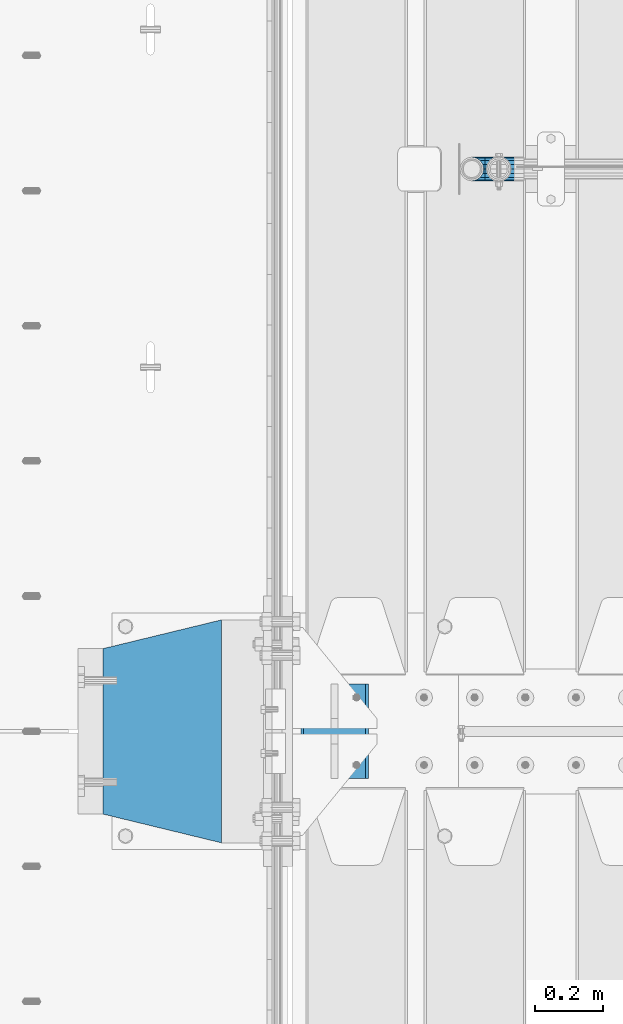
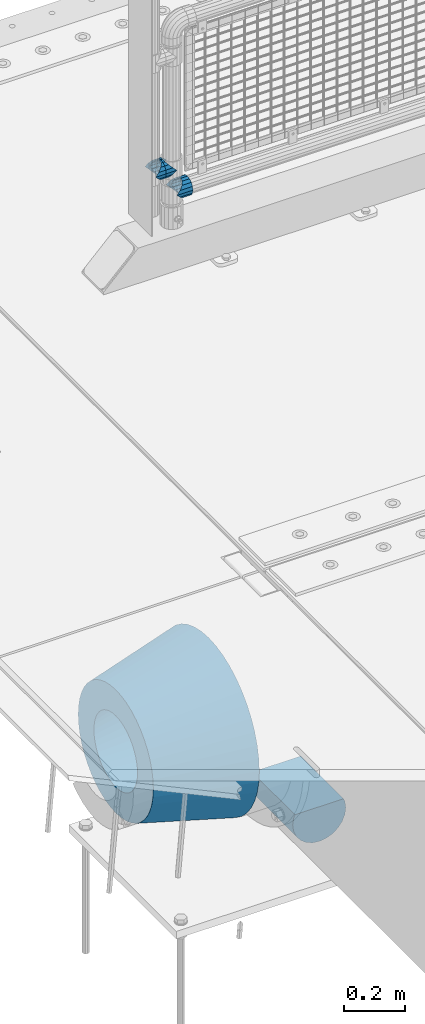
# One storey, part 145 of 257: 5 beams.
"""IFC2X3 building model written with IfcOpenShell, lengths in millimetres."""

from ifc_helpers import new_model, si_unit, frame, origin_with_axes, place, context, subcontext, project, spatial, faceted_brep, material, type_object, element, save


model = new_model("IFC2X3")

# Units and contexts
model_context = context("Model", 3, precision=1e-05, world=origin_with_axes())
body_context = subcontext(model_context, "Body", "Model", "MODEL_VIEW")
ifc_project = project(units=[si_unit("LENGTHUNIT", "METRE", prefix="MILLI"), si_unit("AREAUNIT", "SQUARE_METRE"), si_unit("VOLUMEUNIT", "CUBIC_METRE"), si_unit("MASSUNIT", "GRAM", prefix="KILO"), si_unit("TIMEUNIT", "SECOND"), si_unit("PLANEANGLEUNIT", "RADIAN"), si_unit("SOLIDANGLEUNIT", "STERADIAN"), si_unit("THERMODYNAMICTEMPERATUREUNIT", "DEGREE_CELSIUS"), si_unit("LUMINOUSINTENSITYUNIT", "LUMEN")], contexts=[model_context])

# Site, building, storey
site_placement = place(None, origin_with_axes())
site = spatial("IfcSite", under=ifc_project, at=site_placement, CompositionType="ELEMENT")
building_placement = place(site_placement, origin_with_axes())
building = spatial("IfcBuilding", under=site, at=building_placement, Name="Standard", CompositionType="ELEMENT")
storey_placement = place(building_placement, origin_with_axes())
storey = spatial("IfcBuildingStorey", under=building, at=storey_placement, Name="Undefined", CompositionType="ELEMENT", Elevation=0.0)

# Beams
ifc_material_1 = material(Name="STEEL/S355N")
beam_type_1 = type_object("IfcBeamType", Name="D200", PredefinedType="NOTDEFINED")
beam_1_placement = place(storey_placement, frame((42585.0, 8860.0, -928.0), z_axis=(0.0, 0.0, 1.0), x_axis=(0.0, 1.0, 0.0)))
element("IfcBeam", 1, at=beam_1_placement, inside=storey, type_object=beam_type_1, material=ifc_material_1, ObjectType="D200", context=body_context, shape_type="Brep", body=[
    faceted_brep([(0.0, 100.0, 0.0), (0.0, 96.5925826289094, 25.8819045102521), (280.0, 96.5925826289094, 25.8819045102521), (280.0, 100.0, 0.0), (0.0, 96.5925826289094, -25.8819045102521), (280.0, 96.5925826289094, -25.8819045102521), (0.0, 86.6025403784442, -50.0), (280.0, 86.6025403784442, -50.0), (0.0, 70.7106781186521, -70.7106781186548), (280.0, 70.7106781186521, -70.7106781186548), (0.0, 50.0, -86.6025403784438), (280.0, 50.0, -86.6025403784438), (0.0, 25.88190451025, -96.5925826289067), (280.0, 25.88190451025, -96.5925826289067), (0.0, 0.0, -100.0), (280.0, 0.0, -100.0), (0.0, -25.88190451025, -96.5925826289069), (280.0, -25.88190451025, -96.5925826289069), (0.0, -50.0, -86.6025403784439), (280.0, -50.0, -86.6025403784439), (0.0, -70.7106781186521, -70.7106781186548), (280.0, -70.7106781186521, -70.7106781186548), (0.0, -86.6025403784442, -50.0), (280.0, -86.6025403784442, -50.0), (0.0, -96.5925826289094, -25.8819045102522), (280.0, -96.5925826289094, -25.8819045102522), (0.0, -100.0, 0.0), (280.0, -100.0, 0.0), (0.0, -96.5925826289094, 25.8819045102521), (280.0, -96.5925826289094, 25.8819045102521), (280.0, -91.5731031269243, 38.0), (0.0, -91.5731031269243, 38.0), (0.0, 91.5731031269243, 38.0), (280.0, 91.5731031269243, 38.0)], [[[0, 1, 2, 3]], [[4, 0, 3, 5]], [[6, 4, 5, 7]], [[8, 6, 7, 9]], [[10, 8, 9, 11]], [[12, 10, 11, 13]], [[14, 12, 13, 15]], [[16, 14, 15, 17]], [[18, 16, 17, 19]], [[20, 18, 19, 21]], [[22, 20, 21, 23]], [[24, 22, 23, 25]], [[26, 24, 25, 27]], [[28, 26, 27, 29]], [[28, 29, 30, 31]], [[1, 0, 4, 6, 8, 10, 12, 14, 16, 18, 20, 22, 24, 26, 28, 31, 32]], [[2, 1, 32, 33]], [[29, 27, 25, 23, 21, 19, 17, 15, 13, 11, 9, 7, 5, 3, 2, 33, 30]], [[32, 31, 30, 33]]]),
])
ifc_material_2 = material(Name="Misc_Undefined")
beam_type_2 = type_object("IfcBeamType", PredefinedType="NOTDEFINED")
beam_2_placement = place(storey_placement, frame((43071.0, 10664.5, 298.67), z_axis=(0.0, 1.0, 0.0), x_axis=(1.0, 0.0, 0.0)))
element("IfcBeam", 2, at=beam_2_placement, inside=storey, type_object=beam_type_2, material=ifc_material_2, context=body_context, shape_type="Brep", body=[
    faceted_brep([(0.0, 0.0, 35.1499999999996), (13.4513226476338, 13.4513226476329, 32.4743655677721), (13.4513226476338, -13.4513226476329, 32.4743655677721), (32.4743655677739, -32.4743655677717, -13.4513226476338), (32.4743655677739, -26.8123795176755, -13.4513226476338), (27.1226768591005, -21.4606908090117, -21.4606908090118), (24.8548033587067, -16.3810424080045, -24.8548033587067), (24.8548033587067, -24.8548033587072, -24.8548033587067), (13.4513226476338, -13.4513226476329, -32.4743655677721), (13.4513226476338, 13.4513226476329, -32.4743655677721), (0.0, 0.0, -35.1499999999996), (20.0882031229849, -11.6144421722805, -28.0397438117179), (16.6306603983685, 0.0, -30.3500000000004), (20.0882031229849, 11.6144421722805, -28.0397438117179), (24.8548033587067, 16.3810424080013, -24.8548033587067), (24.8548033587067, 24.8548033587072, -24.8548033587067), (32.4743655677739, 26.8123795176754, -13.4513226476338), (32.4743655677739, 32.4743655677717, -13.4513226476338), (27.1226768591005, 21.4606908090117, -21.4606908090118), (35.1500000000015, 30.35, 0.0), (35.1500000000015, 35.15, 0.0), (32.8397438117172, 28.0397438117175, -11.6144421722802), (32.8397438117172, 28.0397438117175, 11.6144421722802), (32.4743655677739, 26.8123795176755, 13.4513226476338), (32.4743655677739, 32.4743655677717, 13.4513226476338), (27.122676859115, 21.4606908090117, 21.4606908090118), (24.8548033587067, 16.3810424080013, 24.8548033587067), (24.8548033587067, 24.8548033587072, 24.8548033587067), (20.0882031229849, 11.6144421722805, 28.0397438117179), (16.6306603983758, 0.0, 30.3500000000004), (20.0882031229849, -11.6144421722805, 28.0397438117179), (24.8548033587067, -16.3810424080013, 24.8548033587067), (24.8548033587067, -24.8548033587072, 24.8548033587067), (27.122676859115, -21.4606908090117, 21.4606908090118), (32.4743655677739, -26.8123795176754, 13.4513226476338), (32.4743655677739, -32.4743655677717, 13.4513226476338), (32.8397438117172, -28.0397438117175, 11.6144421722802), (35.1500000000015, -30.35, 0.0), (35.1500000000015, -35.1499999999996, 0.0), (32.8397438117172, -28.0397438117175, -11.6144421722802), (60.1500000000015, -24.8548033587072, -24.8548033587067), (60.1500000000015, -32.4743655677717, -13.4513226476338), (60.1500000000015, -13.4513226476329, -32.4743655677721), (60.1500000000015, 0.0, -35.1499999999996), (60.1500000000015, 13.4513226476329, -32.4743655677721), (60.1500000000015, 24.8548033587072, -24.8548033587067), (60.1500000000015, 32.4743655677717, -13.4513226476338), (60.1500000000015, 35.15, 0.0), (60.1500000000015, 32.4743655677717, 13.4513226476338), (60.1500000000015, 24.8548033587072, 24.8548033587067), (60.1500000000015, 13.4513226476329, 32.4743655677721), (60.1500000000015, 0.0, 35.1499999999996), (60.1500000000015, -13.4513226476329, 32.4743655677721), (60.1500000000015, -24.8548033587072, 24.8548033587067), (60.1500000000015, -32.4743655677717, 13.4513226476338), (60.1500000000015, -35.15, 0.0), (60.1500000000015, -21.4606908090117, 21.4606908090118), (60.1500000000015, -11.6144421722805, 28.0397438117179), (60.1500000000015, 0.0, 30.3500000000004), (60.1500000000015, 11.6144421722805, 28.0397438117179), (60.1500000000015, 21.4606908090117, 21.4606908090118), (60.1500000000015, 28.0397438117175, 11.6144421722802), (60.1500000000015, 30.35, 0.0), (60.1500000000015, 28.0397438117175, -11.6144421722802), (60.1500000000015, 21.4606908090117, -21.4606908090118), (60.1500000000015, 11.6144421722805, -28.0397438117179), (60.1500000000015, 0.0, -30.3500000000004), (60.1500000000015, -11.6144421722805, -28.0397438117179), (60.1500000000015, -21.4606908090117, -21.4606908090118), (60.1500000000015, -28.0397438117175, -11.6144421722802), (60.1500000000015, -30.35, 0.0), (60.1500000000015, -28.0397438117175, 11.6144421722802)], [[[0, 1, 2]], [[3, 4, 5, 6, 7]], [[8, 9, 10]], [[7, 6, 11, 12, 13, 14, 15, 9, 8]], [[16, 17, 15, 14, 18]], [[19, 20, 17, 16, 21]], [[22, 23, 24, 20, 19]], [[25, 26, 27, 24, 23]], [[2, 1, 27, 26, 28, 29, 30, 31, 32]], [[32, 31, 33, 34, 35]], [[35, 34, 36, 37, 38]], [[38, 37, 39, 4, 3]], [[40, 41, 3, 7]], [[42, 40, 7, 8]], [[43, 42, 8, 10]], [[44, 43, 10, 9]], [[45, 44, 9, 15]], [[46, 45, 15, 17]], [[47, 46, 17, 20]], [[48, 47, 20, 24]], [[49, 48, 24, 27]], [[50, 49, 27, 1]], [[51, 50, 1, 0]], [[52, 51, 0, 2]], [[53, 52, 2, 32]], [[54, 53, 32, 35]], [[55, 54, 35, 38]], [[41, 55, 38, 3]], [[40, 42, 43, 44, 45, 46, 47, 48, 49, 50, 51, 52, 53, 54, 55, 41], [56, 57, 58, 59, 60, 61, 62, 63, 64, 65, 66, 67, 68, 69, 70, 71]], [[71, 70, 37, 36]], [[33, 56, 71, 36, 34]], [[30, 57, 56, 33, 31]], [[58, 57, 30, 29]], [[59, 58, 29, 28]], [[60, 59, 28, 26, 25]], [[61, 60, 25, 23, 22]], [[62, 61, 22, 19]], [[63, 62, 19, 21]], [[18, 64, 63, 21, 16]], [[13, 65, 64, 18, 14]], [[66, 65, 13, 12]], [[67, 66, 12, 11]], [[68, 67, 11, 6, 5]], [[69, 68, 5, 4, 39]], [[70, 69, 39, 37]]]),
])
beam_3_placement = place(storey_placement, frame((42991.0, 10664.5, 398.669999999999), z_axis=(0.0, -1.0, 0.0), x_axis=(1.0, 0.0, 0.0)))
element("IfcBeam", 3, at=beam_3_placement, inside=storey, type_object=beam_type_2, material=ifc_material_2, context=body_context, shape_type="Brep", body=[
    faceted_brep([(13.4513226476338, -13.4513226476329, -32.4743655677721), (13.4513226476338, 13.4513226476329, -32.4743655677721), (0.0, 0.0, -35.1499999999996), (27.122676859115, 21.4606908090117, 21.4606908090118), (24.8548033587067, 16.3810424080013, 24.8548033587067), (24.8548033587067, 24.8548033587072, 24.8548033587067), (32.4743655677739, 32.4743655677717, 13.4513226476338), (32.4743655677739, 26.8123795176755, 13.4513226476338), (0.0, 0.0, 35.1499999999996), (13.4513226476338, 13.4513226476329, 32.4743655677721), (13.4513226476338, -13.4513226476329, 32.4743655677721), (20.0882031229849, 11.6144421722805, 28.0397438117179), (16.6306603983758, 0.0, 30.3500000000004), (20.0882031229849, -11.6144421722805, 28.0397438117179), (24.8548033587067, -16.3810424080013, 24.8548033587067), (24.8548033587067, -24.8548033587072, 24.8548033587067), (27.122676859115, -21.4606908090117, 21.4606908090118), (32.4743655677739, -26.8123795176754, 13.4513226476338), (32.4743655677739, -32.4743655677717, 13.4513226476338), (32.8397438117172, -28.0397438117175, 11.6144421722802), (35.1500000000015, -30.35, 0.0), (35.1500000000015, -35.1499999999996, 0.0), (32.8397438117172, -28.0397438117175, -11.6144421722802), (32.4743655677739, -26.8123795176755, -13.4513226476338), (32.4743655677739, -32.4743655677717, -13.4513226476338), (27.1226768591005, -21.4606908090117, -21.4606908090118), (24.8548033587067, -16.3810424080045, -24.8548033587067), (24.8548033587067, -24.8548033587072, -24.8548033587067), (20.0882031229849, -11.6144421722805, -28.0397438117179), (16.6306603983685, 0.0, -30.3500000000004), (20.0882031229849, 11.6144421722805, -28.0397438117179), (24.8548033587067, 16.3810424080013, -24.8548033587067), (24.8548033587067, 24.8548033587072, -24.8548033587067), (32.4743655677739, 26.8123795176754, -13.4513226476338), (32.4743655677739, 32.4743655677717, -13.4513226476338), (27.1226768591005, 21.4606908090117, -21.4606908090118), (35.1500000000015, 30.35, 0.0), (35.1500000000015, 35.15, 0.0), (32.8397438117172, 28.0397438117175, -11.6144421722802), (32.8397438117172, 28.0397438117175, 11.6144421722802), (40.1500000000015, -35.15, 0.0), (40.1500000000015, -32.4743655677717, 13.4513226476338), (40.1500000000015, -24.8548033587072, 24.8548033587067), (40.1500000000015, -13.4513226476329, 32.4743655677721), (40.1500000000015, 0.0, 35.1499999999996), (40.1500000000015, 13.4513226476329, 32.4743655677721), (40.1500000000015, 24.8548033587072, 24.8548033587067), (40.1500000000015, 32.4743655677717, 13.4513226476338), (40.1500000000015, 35.15, 0.0), (40.1500000000015, -24.8548033587072, -24.8548033587067), (40.1500000000015, -32.4743655677717, -13.4513226476338), (40.1500000000015, -13.4513226476329, -32.4743655677721), (40.1500000000015, 0.0, -35.1499999999996), (40.1500000000015, 13.4513226476329, -32.4743655677721), (40.1500000000015, 24.8548033587072, -24.8548033587067), (40.1500000000015, 32.4743655677717, -13.4513226476338), (40.1500000000015, -21.4606908090117, 21.4606908090118), (40.1500000000015, -11.6144421722805, 28.0397438117179), (40.1500000000015, 0.0, 30.3500000000004), (40.1500000000015, 11.6144421722805, 28.0397438117179), (40.1500000000015, 21.4606908090117, 21.4606908090118), (40.1500000000015, 28.0397438117175, 11.6144421722802), (40.1500000000015, 30.35, 0.0), (40.1500000000015, 28.0397438117175, -11.6144421722802), (40.1500000000015, 21.4606908090117, -21.4606908090118), (40.1500000000015, 11.6144421722805, -28.0397438117179), (40.1500000000015, 0.0, -30.3500000000004), (40.1500000000015, -11.6144421722805, -28.0397438117179), (40.1500000000015, -21.4606908090117, -21.4606908090118), (40.1500000000015, -28.0397438117175, -11.6144421722802), (40.1500000000015, -30.35, 0.0), (40.1500000000015, -28.0397438117175, 11.6144421722802)], [[[0, 1, 2]], [[3, 4, 5, 6, 7]], [[8, 9, 10]], [[10, 9, 5, 4, 11, 12, 13, 14, 15]], [[15, 14, 16, 17, 18]], [[18, 17, 19, 20, 21]], [[21, 20, 22, 23, 24]], [[24, 23, 25, 26, 27]], [[27, 26, 28, 29, 30, 31, 32, 1, 0]], [[33, 34, 32, 31, 35]], [[36, 37, 34, 33, 38]], [[39, 7, 6, 37, 36]], [[40, 41, 18, 21]], [[41, 42, 15, 18]], [[42, 43, 10, 15]], [[43, 44, 8, 10]], [[44, 45, 9, 8]], [[45, 46, 5, 9]], [[46, 47, 6, 5]], [[47, 48, 37, 6]], [[49, 50, 24, 27]], [[51, 49, 27, 0]], [[52, 51, 0, 2]], [[53, 52, 2, 1]], [[54, 53, 1, 32]], [[55, 54, 32, 34]], [[48, 55, 34, 37]], [[50, 40, 21, 24]], [[49, 51, 52, 53, 54, 55, 48, 47, 46, 45, 44, 43, 42, 41, 40, 50], [56, 57, 58, 59, 60, 61, 62, 63, 64, 65, 66, 67, 68, 69, 70, 71]], [[63, 62, 36, 38]], [[35, 64, 63, 38, 33]], [[30, 65, 64, 35, 31]], [[66, 65, 30, 29]], [[67, 66, 29, 28]], [[68, 67, 28, 26, 25]], [[69, 68, 25, 23, 22]], [[70, 69, 22, 20]], [[71, 70, 20, 19]], [[16, 56, 71, 19, 17]], [[13, 57, 56, 16, 14]], [[58, 57, 13, 12]], [[59, 58, 12, 11]], [[60, 59, 11, 4, 3]], [[61, 60, 3, 7, 39]], [[62, 61, 39, 36]]]),
])
beam_4_placement = place(storey_placement, frame((43071.0, 10664.5, 398.669999999999), z_axis=(0.0, 1.0, 0.0), x_axis=(-1.0, 0.0, 0.0)))
element("IfcBeam", 4, at=beam_4_placement, inside=storey, type_object=beam_type_2, material=ifc_material_2, context=body_context, shape_type="Brep", body=[
    faceted_brep([(13.4513226476338, -13.4513226476329, -32.4743655677721), (13.4513226476338, 13.4513226476329, -32.4743655677721), (0.0, 0.0, -35.1499999999996), (24.8548033587067, -24.8548033587072, 24.8548033587067), (24.8548033587067, -16.3810424080013, 24.8548033587067), (27.122676859115, -21.4606908090117, 21.4606908090118), (32.4743655677739, -26.8123795176754, 13.4513226476338), (32.4743655677739, -32.4743655677717, 13.4513226476338), (32.8397438117172, -28.0397438117175, 11.6144421722802), (35.1500000000015, -30.35, 0.0), (35.1500000000015, -35.1499999999996, 0.0), (32.8397438117172, -28.0397438117175, -11.6144421722802), (32.4743655677739, -26.8123795176755, -13.4513226476338), (32.4743655677739, -32.4743655677717, -13.4513226476338), (27.1226768591005, -21.4606908090117, -21.4606908090118), (24.8548033587067, -16.3810424080045, -24.8548033587067), (24.8548033587067, -24.8548033587072, -24.8548033587067), (20.0882031229849, -11.6144421722805, -28.0397438117179), (16.6306603983685, 0.0, -30.3500000000004), (20.0882031229849, 11.6144421722805, -28.0397438117179), (24.8548033587067, 16.3810424080013, -24.8548033587067), (24.8548033587067, 24.8548033587072, -24.8548033587067), (32.4743655677739, 26.8123795176754, -13.4513226476338), (32.4743655677739, 32.4743655677717, -13.4513226476338), (27.1226768591005, 21.4606908090117, -21.4606908090118), (35.1500000000015, 30.35, 0.0), (35.1500000000015, 35.15, 0.0), (32.8397438117172, 28.0397438117175, -11.6144421722802), (32.8397438117172, 28.0397438117175, 11.6144421722802), (32.4743655677739, 26.8123795176755, 13.4513226476338), (32.4743655677739, 32.4743655677717, 13.4513226476338), (27.122676859115, 21.4606908090117, 21.4606908090118), (24.8548033587067, 16.3810424080013, 24.8548033587067), (24.8548033587067, 24.8548033587072, 24.8548033587067), (0.0, 0.0, 35.1499999999996), (13.4513226476338, 13.4513226476329, 32.4743655677721), (13.4513226476338, -13.4513226476329, 32.4743655677721), (20.0882031229849, 11.6144421722805, 28.0397438117179), (16.6306603983758, 0.0, 30.3500000000004), (20.0882031229849, -11.6144421722805, 28.0397438117179), (40.1500000000015, -35.15, 0.0), (40.1500000000015, -32.4743655677717, 13.4513226476338), (40.1500000000015, -24.8548033587072, 24.8548033587067), (40.1500000000015, -13.4513226476329, 32.4743655677721), (40.1500000000015, 0.0, 35.1499999999996), (40.1500000000015, -24.8548033587072, -24.8548033587067), (40.1500000000015, -32.4743655677717, -13.4513226476338), (40.1500000000015, -13.4513226476329, -32.4743655677721), (40.1500000000015, 0.0, -35.1499999999996), (40.1500000000015, 13.4513226476329, -32.4743655677721), (40.1500000000015, 24.8548033587072, -24.8548033587067), (40.1500000000015, 32.4743655677717, -13.4513226476338), (40.1500000000015, 35.15, 0.0), (40.1500000000015, 32.4743655677717, 13.4513226476338), (40.1500000000015, 24.8548033587072, 24.8548033587067), (40.1500000000015, 13.4513226476329, 32.4743655677721), (40.1500000000015, -21.4606908090117, 21.4606908090118), (40.1500000000015, -11.6144421722805, 28.0397438117179), (40.1500000000015, 0.0, 30.3500000000004), (40.1500000000015, 11.6144421722805, 28.0397438117179), (40.1500000000015, 21.4606908090117, 21.4606908090118), (40.1500000000015, 28.0397438117175, 11.6144421722802), (40.1500000000015, 30.35, 0.0), (40.1500000000015, 28.0397438117175, -11.6144421722802), (40.1500000000015, 21.4606908090117, -21.4606908090118), (40.1500000000015, 11.6144421722805, -28.0397438117179), (40.1500000000015, 0.0, -30.3500000000004), (40.1500000000015, -11.6144421722805, -28.0397438117179), (40.1500000000015, -21.4606908090117, -21.4606908090118), (40.1500000000015, -28.0397438117175, -11.6144421722802), (40.1500000000015, -30.35, 0.0), (40.1500000000015, -28.0397438117175, 11.6144421722802)], [[[0, 1, 2]], [[3, 4, 5, 6, 7]], [[7, 6, 8, 9, 10]], [[10, 9, 11, 12, 13]], [[13, 12, 14, 15, 16]], [[16, 15, 17, 18, 19, 20, 21, 1, 0]], [[22, 23, 21, 20, 24]], [[25, 26, 23, 22, 27]], [[28, 29, 30, 26, 25]], [[31, 32, 33, 30, 29]], [[34, 35, 36]], [[36, 35, 33, 32, 37, 38, 39, 4, 3]], [[40, 41, 7, 10]], [[41, 42, 3, 7]], [[42, 43, 36, 3]], [[43, 44, 34, 36]], [[45, 46, 13, 16]], [[47, 45, 16, 0]], [[48, 47, 0, 2]], [[49, 48, 2, 1]], [[50, 49, 1, 21]], [[51, 50, 21, 23]], [[52, 51, 23, 26]], [[53, 52, 26, 30]], [[54, 53, 30, 33]], [[55, 54, 33, 35]], [[44, 55, 35, 34]], [[46, 40, 10, 13]], [[45, 47, 48, 49, 50, 51, 52, 53, 54, 55, 44, 43, 42, 41, 40, 46], [56, 57, 58, 59, 60, 61, 62, 63, 64, 65, 66, 67, 68, 69, 70, 71]], [[59, 58, 38, 37]], [[60, 59, 37, 32, 31]], [[61, 60, 31, 29, 28]], [[62, 61, 28, 25]], [[63, 62, 25, 27]], [[24, 64, 63, 27, 22]], [[19, 65, 64, 24, 20]], [[66, 65, 19, 18]], [[67, 66, 18, 17]], [[68, 67, 17, 15, 14]], [[69, 68, 14, 12, 11]], [[70, 69, 11, 9]], [[71, 70, 9, 8]], [[5, 56, 71, 8, 6]], [[39, 57, 56, 5, 4]], [[58, 57, 39, 38]]]),
])
ifc_material_3 = material(Name="SCN-500-E2")
beam_type_3 = type_object("IfcBeamType", PredefinedType="NOTDEFINED")
beam_5_placement = place(storey_placement, frame((42250.0, 9000.0, -515.0), z_axis=(0.0, 0.0, 1.0), x_axis=(-1.0, 0.0, 0.0)))
element("IfcBeam", 5, at=beam_5_placement, inside=storey, type_object=beam_type_3, material=ifc_material_3, context=body_context, shape_type="Brep", body=[
    faceted_brep([(0.0, -330.0, 0.0), (0.0, -326.641075820708, -46.9638966301842), (350.0, -242.506253260829, -34.8671353769549), (350.0, -245.0, 0.0), (0.0, -316.632681292784, -92.9717437576718), (350.0, -235.075778535552, -69.0244764261503), (0.0, -300.178558466991, -137.086954290623), (350.0, -222.859838861857, -101.776678185462), (0.0, -277.61366583429, -178.411469760347), (350.0, -206.107115543639, -132.457000276621), (0.0, -249.397359536905, -216.104042201944), (350.0, -185.158645716793, -160.440879816595), (0.0, -216.104042201944, -249.397359536905), (350.0, -160.440879816595, -185.158645716793), (0.0, -178.411469760347, -277.61366583429), (350.0, -132.457000276621, -206.107115543639), (0.0, -137.086954290622, -300.178558466991), (350.0, -101.776678185462, -222.859838861857), (0.0, -92.9717437576717, -316.632681292784), (350.0, -69.0244764261502, -235.075778535552), (0.0, -46.963896630184, -326.641075820708), (350.0, -34.8671353769548, -242.506253260829), (0.0, 6.0620016557794e-14, -330.0), (350.0, 4.50057698686652e-14, -245.0), (0.0, 46.9638966301841, -326.641075820708), (350.0, 34.8671353769549, -242.506253260829), (0.0, 92.9717437576718, -316.632681292784), (350.0, 69.0244764261503, -235.075778535552), (0.0, 137.086954290623, -300.178558466991), (350.0, 101.776678185462, -222.859838861857), (0.0, 178.411469760347, -277.61366583429), (350.0, 132.457000276621, -206.107115543639), (0.0, 216.104042201944, -249.397359536905), (350.0, 160.440879816595, -185.158645716793), (0.0, 249.397359536905, -216.104042201944), (350.0, 185.158645716793, -160.440879816595), (0.0, 277.61366583429, -178.411469760347), (350.0, 206.107115543639, -132.457000276621), (0.0, 300.178558466991, -137.086954290623), (350.0, 222.859838861857, -101.776678185462), (0.0, 316.632681292784, -92.9717437576717), (350.0, 235.075778535552, -69.0244764261502), (0.0, 326.641075820708, -46.9638966301841), (350.0, 242.506253260829, -34.8671353769548), (0.0, 330.0, 0.0), (350.0, 245.0, 0.0), (0.0, 326.641075820708, 46.9638966301841), (350.0, 242.506253260829, 34.8671353769549), (0.0, 316.632681292784, 92.9717437576718), (350.0, 235.075778535552, 69.0244764261503), (0.0, 300.178558466991, 137.086954290622), (350.0, 222.859838861857, 101.776678185462), (0.0, 277.61366583429, 178.411469760347), (350.0, 206.107115543639, 132.457000276621), (0.0, 249.397359536905, 216.104042201944), (350.0, 185.158645716793, 160.440879816595), (0.0, 216.104042201944, 249.397359536905), (350.0, 160.440879816595, 185.158645716793), (0.0, 178.411469760347, 277.61366583429), (350.0, 132.457000276621, 206.107115543639), (0.0, 137.086954290622, 300.178558466991), (350.0, 101.776678185462, 222.859838861857), (0.0, 92.9717437576718, 316.632681292784), (350.0, 69.0244764261503, 235.075778535552), (0.0, 46.9638966301841, 326.641075820708), (350.0, 34.8671353769548, 242.506253260829), (0.0, -2.02066721859313e-14, 330.0), (350.0, -1.50019232895551e-14, 245.0), (0.0, -46.9638966301841, 326.641075820708), (350.0, -34.8671353769549, 242.506253260829), (0.0, -92.9717437576718, 316.632681292784), (350.0, -69.0244764261503, 235.075778535552), (0.0, -137.086954290623, 300.178558466991), (350.0, -101.776678185462, 222.859838861857), (0.0, -178.411469760347, 277.61366583429), (350.0, -132.457000276621, 206.107115543639), (0.0, -216.104042201944, 249.397359536905), (350.0, -160.440879816595, 185.158645716793), (0.0, -249.397359536905, 216.104042201944), (350.0, -185.158645716793, 160.440879816595), (0.0, -277.61366583429, 178.411469760347), (350.0, -206.107115543639, 132.457000276621), (0.0, -300.178558466991, 137.086954290623), (350.0, -222.859838861857, 101.776678185462), (0.0, -316.632681292784, 92.9717437576718), (350.0, -235.075778535552, 69.0244764261503), (0.0, -326.641075820708, 46.9638966301841), (350.0, -242.506253260829, 34.8671353769549), (0.0, -227.093265923131, 0.0), (0.0, -224.781783917484, 32.3187414128026), (350.0, -140.646961357605, 20.2219801595734), (350.0, -142.093265923131, 0.0), (0.0, -217.894393008413, 63.9795664499945), (350.0, -136.337490251181, 40.032299118473), (0.0, -206.571300613232, 94.3379520160985), (350.0, -129.252581008098, 59.0276759109381), (0.0, -191.043012240005, 122.775888927343), (350.0, -119.536461949355, 76.8214194436173), (0.0, -171.625639060125, 148.714462796454), (350.0, -107.386925240013, 93.0513004111044), (0.0, -148.714462796454, 171.625639060125), (350.0, -93.0513004111044, 107.386925240013), (0.0, -122.775888927343, 191.043012240005), (350.0, -76.8214194436173, 119.536461949355), (0.0, -94.3379520160984, 206.571300613232), (350.0, -59.0276759109381, 129.252581008098), (0.0, -63.9795664499945, 217.894393008413), (350.0, -40.032299118473, 136.337490251181), (0.0, -32.3187414128025, 224.781783917484), (350.0, -20.2219801595733, 140.646961357605), (0.0, 4.17163561831022e-14, 227.093265923131), (350.0, 2.61021094939735e-14, 142.093265923131), (0.0, 32.3187414128026, 224.781783917484), (350.0, 20.2219801595734, 140.646961357605), (0.0, 63.9795664499945, 217.894393008413), (350.0, 40.032299118473, 136.337490251181), (0.0, 94.3379520160985, 206.571300613232), (350.0, 59.0276759109381, 129.252581008098), (0.0, 122.775888927343, 191.043012240005), (350.0, 76.8214194436174, 119.536461949355), (0.0, 148.714462796454, 171.625639060125), (350.0, 93.0513004111044, 107.386925240013), (0.0, 171.625639060125, 148.714462796454), (350.0, 107.386925240013, 93.0513004111044), (0.0, 191.043012240005, 122.775888927343), (350.0, 119.536461949355, 76.8214194436174), (0.0, 206.571300613232, 94.3379520160985), (350.0, 129.252581008098, 59.0276759109382), (0.0, 217.894393008413, 63.9795664499945), (350.0, 136.337490251181, 40.032299118473), (0.0, 224.781783917484, 32.3187414128025), (350.0, 140.646961357605, 20.2219801595733), (0.0, 227.093265923131, 0.0), (350.0, 142.093265923131, 0.0), (0.0, 224.781783917484, -32.3187414128026), (350.0, 140.646961357605, -20.2219801595734), (0.0, 217.894393008413, -63.9795664499945), (350.0, 136.337490251181, -40.032299118473), (0.0, 206.571300613232, -94.3379520160985), (350.0, 129.252581008098, -59.0276759109381), (0.0, 191.043012240005, -122.775888927343), (350.0, 119.536461949355, -76.8214194436174), (0.0, 171.625639060125, -148.714462796454), (350.0, 107.386925240013, -93.0513004111044), (0.0, 148.714462796454, -171.625639060125), (350.0, 93.0513004111044, -107.386925240013), (0.0, 122.775888927343, -191.043012240005), (350.0, 76.8214194436174, -119.536461949355), (0.0, 94.3379520160985, -206.571300613232), (350.0, 59.0276759109381, -129.252581008098), (0.0, 63.9795664499945, -217.894393008413), (350.0, 40.032299118473, -136.337490251181), (0.0, 32.3187414128026, -224.781783917484), (350.0, 20.2219801595733, -140.646961357605), (0.0, -1.39054520610341e-14, -227.093265923131), (350.0, -8.70070316465783e-15, -142.093265923131), (0.0, -32.3187414128026, -224.781783917484), (350.0, -20.2219801595733, -140.646961357605), (0.0, -63.9795664499946, -217.894393008413), (350.0, -40.032299118473, -136.337490251181), (0.0, -94.3379520160985, -206.571300613232), (350.0, -59.0276759109381, -129.252581008098), (0.0, -122.775888927343, -191.043012240005), (350.0, -76.8214194436174, -119.536461949355), (0.0, -148.714462796454, -171.625639060125), (350.0, -93.0513004111044, -107.386925240013), (0.0, -171.625639060125, -148.714462796454), (350.0, -107.386925240013, -93.0513004111044), (0.0, -191.043012240005, -122.775888927343), (350.0, -119.536461949355, -76.8214194436174), (0.0, -206.571300613232, -94.3379520160985), (350.0, -129.252581008098, -59.0276759109381), (0.0, -217.894393008413, -63.9795664499945), (350.0, -136.337490251181, -40.032299118473), (0.0, -224.781783917484, -32.3187414128026), (350.0, -140.646961357605, -20.2219801595734)], [[[0, 1, 2, 3]], [[1, 4, 5, 2]], [[4, 6, 7, 5]], [[6, 8, 9, 7]], [[8, 10, 11, 9]], [[10, 12, 13, 11]], [[12, 14, 15, 13]], [[14, 16, 17, 15]], [[16, 18, 19, 17]], [[18, 20, 21, 19]], [[20, 22, 23, 21]], [[22, 24, 25, 23]], [[24, 26, 27, 25]], [[26, 28, 29, 27]], [[28, 30, 31, 29]], [[30, 32, 33, 31]], [[32, 34, 35, 33]], [[34, 36, 37, 35]], [[36, 38, 39, 37]], [[38, 40, 41, 39]], [[40, 42, 43, 41]], [[42, 44, 45, 43]], [[44, 46, 47, 45]], [[46, 48, 49, 47]], [[48, 50, 51, 49]], [[50, 52, 53, 51]], [[52, 54, 55, 53]], [[54, 56, 57, 55]], [[56, 58, 59, 57]], [[58, 60, 61, 59]], [[60, 62, 63, 61]], [[62, 64, 65, 63]], [[64, 66, 67, 65]], [[66, 68, 69, 67]], [[68, 70, 71, 69]], [[70, 72, 73, 71]], [[72, 74, 75, 73]], [[74, 76, 77, 75]], [[76, 78, 79, 77]], [[78, 80, 81, 79]], [[80, 82, 83, 81]], [[82, 84, 85, 83]], [[84, 86, 87, 85]], [[86, 0, 3, 87]], [[88, 89, 90, 91]], [[89, 92, 93, 90]], [[92, 94, 95, 93]], [[94, 96, 97, 95]], [[96, 98, 99, 97]], [[98, 100, 101, 99]], [[100, 102, 103, 101]], [[102, 104, 105, 103]], [[104, 106, 107, 105]], [[106, 108, 109, 107]], [[108, 110, 111, 109]], [[110, 112, 113, 111]], [[112, 114, 115, 113]], [[114, 116, 117, 115]], [[116, 118, 119, 117]], [[118, 120, 121, 119]], [[120, 122, 123, 121]], [[122, 124, 125, 123]], [[124, 126, 127, 125]], [[126, 128, 129, 127]], [[128, 130, 131, 129]], [[130, 132, 133, 131]], [[132, 134, 135, 133]], [[134, 136, 137, 135]], [[136, 138, 139, 137]], [[138, 140, 141, 139]], [[140, 142, 143, 141]], [[142, 144, 145, 143]], [[144, 146, 147, 145]], [[146, 148, 149, 147]], [[148, 150, 151, 149]], [[150, 152, 153, 151]], [[152, 154, 155, 153]], [[154, 156, 157, 155]], [[156, 158, 159, 157]], [[158, 160, 161, 159]], [[160, 162, 163, 161]], [[162, 164, 165, 163]], [[164, 166, 167, 165]], [[166, 168, 169, 167]], [[168, 170, 171, 169]], [[170, 172, 173, 171]], [[172, 174, 175, 173]], [[174, 88, 91, 175]], [[5, 7, 9, 11, 13, 15, 17, 19, 21, 23, 25, 27, 29, 31, 33, 35, 37, 39, 41, 43, 45, 47, 49, 51, 53, 55, 57, 59, 61, 63, 65, 67, 69, 71, 73, 75, 77, 79, 81, 83, 85, 87, 3, 2], [93, 95, 97, 99, 101, 103, 105, 107, 109, 111, 113, 115, 117, 119, 121, 123, 125, 127, 129, 131, 133, 135, 137, 139, 141, 143, 145, 147, 149, 151, 153, 155, 157, 159, 161, 163, 165, 167, 169, 171, 173, 175, 91, 90]], [[86, 84, 82, 80, 78, 76, 74, 72, 70, 68, 66, 64, 62, 60, 58, 56, 54, 52, 50, 48, 46, 44, 42, 40, 38, 36, 34, 32, 30, 28, 26, 24, 22, 20, 18, 16, 14, 12, 10, 8, 6, 4, 1, 0], [174, 172, 170, 168, 166, 164, 162, 160, 158, 156, 154, 152, 150, 148, 146, 144, 142, 140, 138, 136, 134, 132, 130, 128, 126, 124, 122, 120, 118, 116, 114, 112, 110, 108, 106, 104, 102, 100, 98, 96, 94, 92, 89, 88]]]),
])

save(model, "model.ifc")
